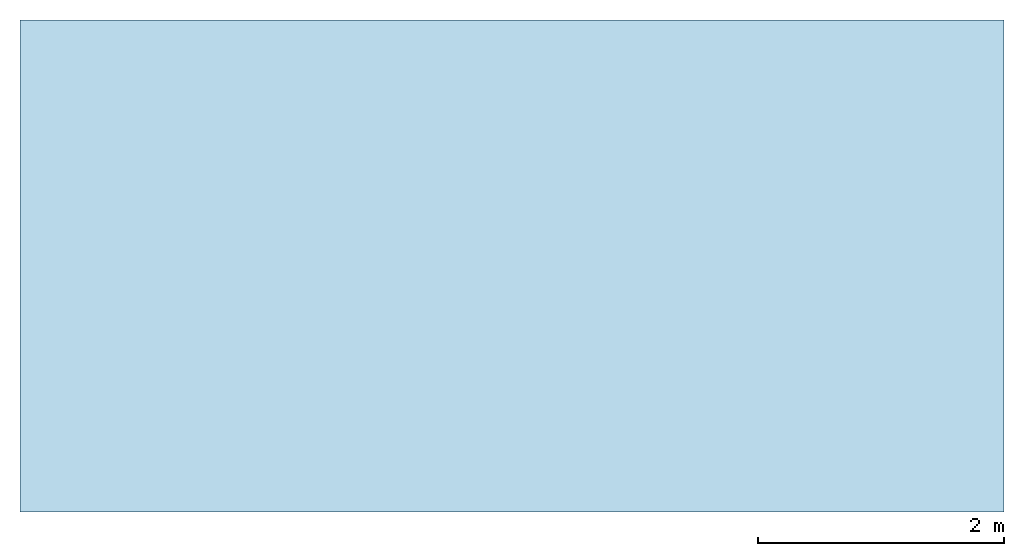
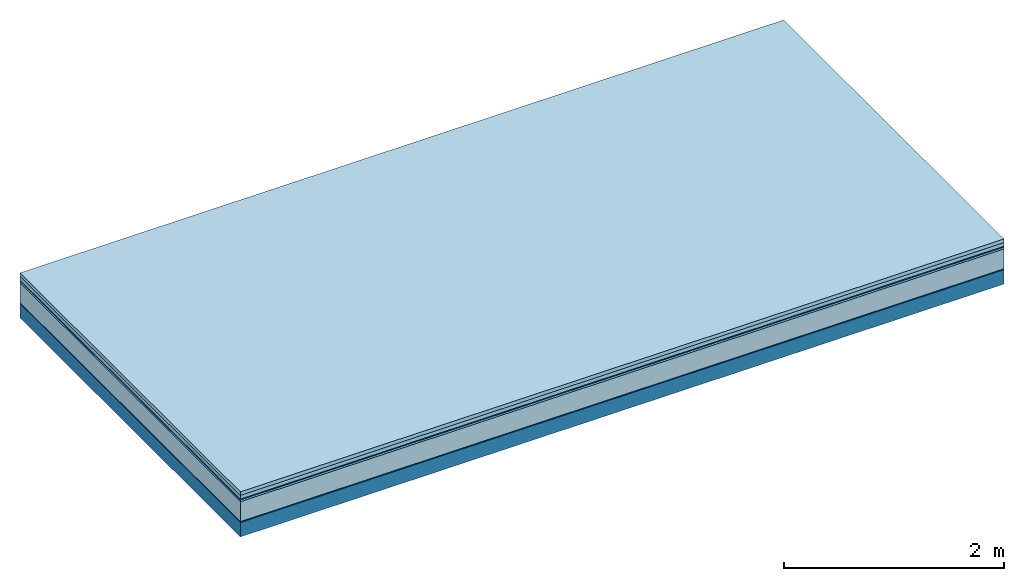
# One storey: 6 plates, 1 member, 1 element without a shape of its own.
"""IFC4 building model written with IfcOpenShell, lengths in metres."""

from ifc_helpers import new_model, si_unit, derived_unit, direction, frame, frame_2d, origin, origin_with_axes, place, context, project, spatial, rectangle, extrude, material, layer, layer_set, type_object, element, aggregate, save


model = new_model("IFC4")

# Units and contexts
plan_context = context("Plan", 3, precision=1e-05, world=origin(), true_north=direction((0.0, 1.0)))
model_context = context("Model", 3, precision=1e-05, world=origin(), true_north=direction((0.0, 1.0)))
ifc_project = project(units=[si_unit("LENGTHUNIT", "METRE"), derived_unit("SOUNDPRESSUREUNIT", [(si_unit("PRESSUREUNIT", "PASCAL", prefix="MICRO"), 0)]), si_unit("ENERGYUNIT", "JOULE", prefix="MEGA"), si_unit("MASSUNIT", "GRAM", prefix="KILO"), derived_unit("THERMALTRANSMITTANCEUNIT", [(si_unit("POWERUNIT", "WATT"), 1), (si_unit("AREAUNIT", "SQUARE_METRE"), -1), (si_unit("THERMODYNAMICTEMPERATUREUNIT", "KELVIN"), -1)]), derived_unit("AREADENSITYUNIT", [(si_unit("MASSUNIT", "GRAM", prefix="KILO"), 1), (si_unit("AREAUNIT", "SQUARE_METRE"), -1)]), derived_unit("USERDEFINED", [(si_unit("ENERGYUNIT", "JOULE", prefix="MEGA"), 1), (si_unit("AREAUNIT", "SQUARE_METRE"), -1)])], contexts=[plan_context, model_context])

# Site, building, storey
site = spatial("IfcSite", under=ifc_project)
building_placement = place(None, origin())
building = spatial("IfcBuilding", under=site, at=building_placement)
storey_placement = place(building_placement, origin())
storey = spatial("IfcBuildingStorey", under=building, at=storey_placement)

# Slab, member, plates
ifc_material_1 = material(Name="Garden plates", Category="02.007")
ifc_layer_1 = layer(ifc_material_1, 0.04, Name="Use and protection layer 3")
ifc_material_2 = material(Name="Gravel 8-16mm", Category="03.011")
ifc_layer_2 = layer(ifc_material_2, 0.04, Name="Use and protection layer 2")
ifc_material_3 = material(Name="Protective layer", Category="09.007")
ifc_layer_3 = layer(ifc_material_3, 0.01, Name="Use and protection layer 1")
ifc_material_4 = material(Name="Bituminous", Category="09.003")
ifc_layer_4 = layer(ifc_material_4, 0.02, Name="Seal")
ifc_material_5 = material(Name="Mineral wool", Category="10.008")
ifc_layer_5 = layer(ifc_material_5, 0.22, Name="Exterior insulation layer 1")
ifc_material_6 = material(Name="Vapor-permeable barrier", Category="09.006")
ifc_layer_6 = layer(ifc_material_6, 0.01, Name="layer / temporary roof")
ifc_material_7 = material(Name="no composite action")
ifc_layer_7 = layer(ifc_material_7, 0.0, Name="Bond")
ifc_layer_8 = layer(None, 0.16, Name="Support")
ifc_layer_set = layer_set([ifc_layer_1, ifc_layer_2, ifc_layer_3, ifc_layer_4, ifc_layer_5, ifc_layer_6, ifc_layer_7, ifc_layer_8])
slab_type = type_object("IfcSlabType", Name="F0050", PredefinedType="NOTDEFINED", material=ifc_layer_set)
slab_placement = place(None, frame((0.0, 0.0, 0.0), z_axis=(0.0, 0.0, -1.0), x_axis=(1.0, 0.0, 0.0)))
slab = element("IfcSlab", 1, at=slab_placement, inside=storey, type_object=slab_type, material=ifc_layer_set, Name="Slab #1")
ifc_material_8 = material(Name="Solid timber panel")
member_placement = place(slab_placement, origin())
member = element("IfcMember", 2, at=member_placement, material=ifc_material_8, Name="Support", context=plan_context, shape_type="SweptSolid", body=[
    extrude(rectangle(XDim=1.0, YDim=0.16, at=frame_2d((0.5, 0.08), x_axis=(1.0, 0.0))), frame((0.0, 4.0, 0.34), z_axis=(0.0, -1.0, 0.0), x_axis=(1.0, 0.0, 0.0)), (0.0, 0.0, 1.0), 4.0),
    extrude(rectangle(XDim=1.0, YDim=0.16, at=frame_2d((0.5, 0.08), x_axis=(1.0, 0.0))), frame((1.0, 4.0, 0.34), z_axis=(0.0, -1.0, 0.0), x_axis=(1.0, 0.0, 0.0)), (0.0, 0.0, 1.0), 4.0),
    extrude(rectangle(XDim=1.0, YDim=0.16, at=frame_2d((0.5, 0.08), x_axis=(1.0, 0.0))), frame((2.0, 4.0, 0.34), z_axis=(0.0, -1.0, 0.0), x_axis=(1.0, 0.0, 0.0)), (0.0, 0.0, 1.0), 4.0),
    extrude(rectangle(XDim=1.0, YDim=0.16, at=frame_2d((0.5, 0.08), x_axis=(1.0, 0.0))), frame((3.0, 4.0, 0.34), z_axis=(0.0, -1.0, 0.0), x_axis=(1.0, 0.0, 0.0)), (0.0, 0.0, 1.0), 4.0),
    extrude(rectangle(XDim=1.0, YDim=0.16, at=frame_2d((0.5, 0.08), x_axis=(1.0, 0.0))), frame((4.0, 4.0, 0.34), z_axis=(0.0, -1.0, 0.0), x_axis=(1.0, 0.0, 0.0)), (0.0, 0.0, 1.0), 4.0),
    extrude(rectangle(XDim=1.0, YDim=0.16, at=frame_2d((0.5, 0.08), x_axis=(1.0, 0.0))), frame((5.0, 4.0, 0.34), z_axis=(0.0, -1.0, 0.0), x_axis=(1.0, 0.0, 0.0)), (0.0, 0.0, 1.0), 4.0),
    extrude(rectangle(XDim=1.0, YDim=0.16, at=frame_2d((0.5, 0.08), x_axis=(1.0, 0.0))), frame((6.0, 4.0, 0.34), z_axis=(0.0, -1.0, 0.0), x_axis=(1.0, 0.0, 0.0)), (0.0, 0.0, 1.0), 4.0),
    extrude(rectangle(XDim=1.0, YDim=0.16, at=frame_2d((0.5, 0.08), x_axis=(1.0, 0.0))), frame((7.0, 4.0, 0.34), z_axis=(0.0, -1.0, 0.0), x_axis=(1.0, 0.0, 0.0)), (0.0, 0.0, 1.0), 4.0),
])
plate_1_placement = place(slab_placement, origin())
plate_1 = element("IfcPlate", 3, at=plate_1_placement, material=ifc_material_1, Name="Use and protection layer 3", context=plan_context, shape_type="SweptSolid", body=[
    extrude(rectangle(XDim=8.0, YDim=4.0, at=frame_2d((4.0, 2.0), x_axis=(1.0, 0.0))), origin_with_axes(), (0.0, 0.0, 1.0), 0.04),
])
plate_2_placement = place(slab_placement, origin())
plate_2 = element("IfcPlate", 4, at=plate_2_placement, material=ifc_material_2, Name="Use and protection layer 2", context=plan_context, shape_type="SweptSolid", body=[
    extrude(rectangle(XDim=8.0, YDim=4.0, at=frame_2d((4.0, 2.0), x_axis=(1.0, 0.0))), frame((0.0, 0.0, 0.04), z_axis=(0.0, 0.0, 1.0), x_axis=(1.0, 0.0, 0.0)), (0.0, 0.0, 1.0), 0.04),
])
plate_3_placement = place(slab_placement, origin())
plate_3 = element("IfcPlate", 5, at=plate_3_placement, material=ifc_material_3, Name="Use and protection layer 1", context=plan_context, shape_type="SweptSolid", body=[
    extrude(rectangle(XDim=8.0, YDim=4.0, at=frame_2d((4.0, 2.0), x_axis=(1.0, 0.0))), frame((0.0, 0.0, 0.08), z_axis=(0.0, 0.0, 1.0), x_axis=(1.0, 0.0, 0.0)), (0.0, 0.0, 1.0), 0.01),
])
plate_4_placement = place(slab_placement, origin())
plate_4 = element("IfcPlate", 6, at=plate_4_placement, material=ifc_material_4, Name="Seal", context=plan_context, shape_type="SweptSolid", body=[
    extrude(rectangle(XDim=8.0, YDim=4.0, at=frame_2d((4.0, 2.0), x_axis=(1.0, 0.0))), frame((0.0, 0.0, 0.09), z_axis=(0.0, 0.0, 1.0), x_axis=(1.0, 0.0, 0.0)), (0.0, 0.0, 1.0), 0.02),
])
plate_5_placement = place(slab_placement, origin())
plate_5 = element("IfcPlate", 7, at=plate_5_placement, material=ifc_material_5, Name="Exterior insulation layer 1", context=plan_context, shape_type="SweptSolid", body=[
    extrude(rectangle(XDim=8.0, YDim=4.0, at=frame_2d((4.0, 2.0), x_axis=(1.0, 0.0))), frame((0.0, 0.0, 0.11), z_axis=(0.0, 0.0, 1.0), x_axis=(1.0, 0.0, 0.0)), (0.0, 0.0, 1.0), 0.22),
])
plate_6_placement = place(slab_placement, origin())
plate_6 = element("IfcPlate", 8, at=plate_6_placement, material=ifc_material_6, Name="layer / temporary roof", context=plan_context, shape_type="SweptSolid", body=[
    extrude(rectangle(XDim=8.0, YDim=4.0, at=frame_2d((4.0, 2.0), x_axis=(1.0, 0.0))), frame((0.0, 0.0, 0.33), z_axis=(0.0, 0.0, 1.0), x_axis=(1.0, 0.0, 0.0)), (0.0, 0.0, 1.0), 0.01),
])
aggregate(slab, [plate_1, plate_2, plate_3, plate_4, plate_5, plate_6, member])

save(model, "model.ifc")
